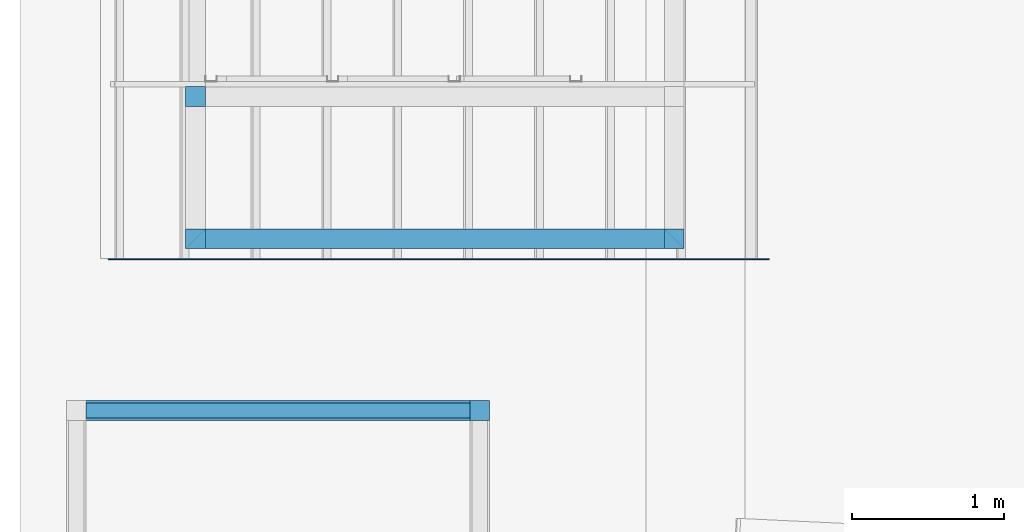
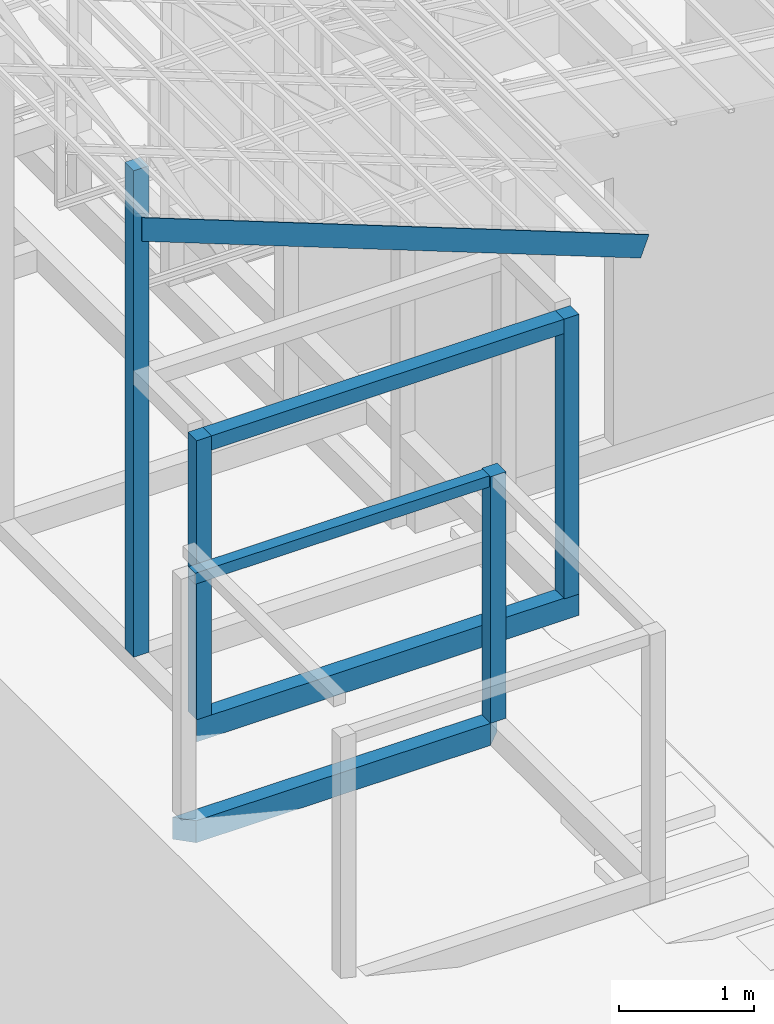
# One storey, part 2 of 22: 8 beams, 1 member.
"""IFC4 building model written with IfcOpenShell, lengths in millimetres."""

from ifc_helpers import new_model, entity, si_unit, converted_unit, frame, origin_with_axes, origin_2d_with_axis, place, context, subcontext, project, spatial, indexed_curve, rectangle, outline, extrude, clip, halfspace, material, material_profile, profile_set, profile_usage, type_object, element, save


model = new_model("IFC4")

# Units and contexts
model_context = context("Model", 3, precision=1e-05, world=origin_with_axes())
plan_context = context("Plan", 2, precision=1e-05, world=origin_2d_with_axis())
body_context = subcontext(model_context, "Body", "Model", "MODEL_VIEW")
ifc_project = project(units=[si_unit("VOLUMEUNIT", "CUBIC_METRE"), si_unit("LENGTHUNIT", "METRE", prefix="MILLI"), si_unit("AREAUNIT", "SQUARE_METRE"), converted_unit("PLANEANGLEUNIT", "degree", entity("IfcReal", 0.0174532925199433), si_unit("PLANEANGLEUNIT", "RADIAN"), dimensions=[0, 0, 0, 0, 0, 0, 0])], contexts=[model_context, plan_context])

# Site, building, storey
site_placement = place(None, origin_with_axes())
site = spatial("IfcSite", under=ifc_project, at=site_placement)
building_placement = place(site_placement, origin_with_axes())
building = spatial("IfcBuilding", under=site, at=building_placement, Name="2")
storey_placement = place(building_placement, frame((0.0, 0.0, 200.000002980232), z_axis=(0.0, 0.0, 1.0), x_axis=(1.0, 0.0, 0.0)))
storey = spatial("IfcBuildingStorey", under=building, at=storey_placement)

# Beams
ifc_material_1 = material(Name="Concrete")
ifc_material_profile_1 = material_profile(ifc_material_1, outline(indexed_curve([(-65.0, 99.9999923706055), (65.0, 99.9999923706055), (65.0, -99.9999923706055), (-65.0, -99.9999923706055), (-65.0, 99.9999923706055)])))
ifc_profile_set_1 = profile_set([ifc_material_profile_1])
ifc_profile_usage_1 = profile_usage(ifc_profile_set_1, cardinal=2)
beam_type_1 = type_object("IfcBeamType", PredefinedType="BEAM", material=ifc_profile_set_1)
beam_1_placement = place(storey_placement, frame((-7215.00015258789, 4065.00482559204, 535.000011324883), z_axis=(0.999999999999932, -1.9470714107682e-07, 3.13916473260157e-07), x_axis=(1.94707183709391e-07, 0.99999999999997, -1.49011611938472e-07)))
element("IfcBeam", 1, at=beam_1_placement, inside=storey, type_object=beam_type_1, material=ifc_profile_usage_1, Name="Beam", PredefinedType="BEAM", context=body_context, shape_type="Clipping", body=[
    clip(clip(extrude(outline(indexed_curve([(-65.0, 99.9999923706055), (65.0, 99.9999923706055), (65.0, -99.9999923706055), (-65.0, -99.9999923706055), (-65.0, 99.9999923706055)])), frame((0.0, 100.0, 0.0), z_axis=(0.0, 0.0, 1.0), x_axis=(1.0, 0.0, 0.0)), (0.0, 0.0, 1.0), 3280.00421035329), halfspace(frame((-65.0003477931023, -735.001564025879, 3280.00473976135), z_axis=(0.70710688829422, -1.95662650526174e-07, 0.707106649875641), x_axis=(-2.76708732110036e-07, -0.999999999999962, 0.0)), False)), halfspace(frame((-65.0000348687172, -735.000491142273, -0.000301992457707456), z_axis=(0.707106649875641, 2.43045974457345e-07, -0.70710688829422), x_axis=(3.43718977186929e-07, -0.999999999999941, 0.0)), False)),
])
ifc_profile_usage_2 = profile_usage(ifc_profile_set_1, cardinal=1)
beam_2_placement = place(storey_placement, frame((-7999.99475479126, 3000.00619888306, 534.999772906304), z_axis=(0.999999999999535, -5.52334881831227e-07, 7.90753631462936e-07), x_axis=(5.52335052361641e-07, 0.999999999999819, -2.38418493836391e-07)))
element("IfcBeam", 2, at=beam_2_placement, inside=storey, type_object=beam_type_1, material=ifc_profile_usage_2, Name="Beam", PredefinedType="BEAM", context=body_context, shape_type="Clipping", body=[
    clip(clip(extrude(outline(indexed_curve([(-65.0, 99.9999923706055), (65.0, 99.9999923706055), (65.0, -99.9999923706055), (-65.0, -99.9999923706055), (-65.0, 99.9999923706055)])), frame((-65.0000076293945, 100.0, 0.0), z_axis=(0.0, 0.0, 1.0), x_axis=(1.0, 0.0, 0.0)), (0.0, 0.0, 1.0), 2785.00036202087), halfspace(frame((-1.94011402498973e-05, -735.002815723419, 2784.99960899353), z_axis=(-0.707106351852417, -5.42005977877125e-07, 0.707107186317444), x_axis=(-7.66512670204509e-07, 0.999999999999706, 0.0)), False)), halfspace(frame((0.0001112751917276, -734.999299049377, -0.000703333228102565), z_axis=(-0.707107186317444, 6.65917013975559e-07, -0.707106351852417), x_axis=(9.41748333012007e-07, 0.999999999999557, 0.0)), False)),
])
ifc_material_profile_2 = material_profile(ifc_material_1, rectangle(XDim=130.000015258789, YDim=130.000015258789, kind="CURVE"))
ifc_profile_set_2 = profile_set([ifc_material_profile_2])
ifc_profile_usage_3 = profile_usage(ifc_profile_set_2, cardinal=5)
beam_type_2 = type_object("IfcBeamType", PredefinedType="BEAM", material=ifc_profile_set_2)
beam_3_placement = place(storey_placement, frame((-7150.00057220459, 4065.00482559204, 735.000118613243), z_axis=(0.0, 0.0, 1.0), x_axis=(1.0, 0.0, 0.0)))
element("IfcBeam", 3, at=beam_3_placement, inside=storey, type_object=beam_type_2, material=ifc_profile_usage_3, Name="Column", PredefinedType="BEAM", context=body_context, shape_type="SweptSolid", body=[
    extrude(rectangle(XDim=130.000015258789, YDim=130.000015258789, kind="CURVE"), origin_with_axes(), (0.0, 0.0, 1.0), 2530.00355867279),
])
ifc_profile_usage_4 = profile_usage(ifc_profile_set_2, cardinal=5)
beam_4_placement = place(storey_placement, frame((-3999.99856948853, 4065.00434875488, 728.171870112419), z_axis=(0.0, 0.0, 1.0), x_axis=(1.0, 0.0, 0.0)))
element("IfcBeam", 4, at=beam_4_placement, inside=storey, type_object=beam_type_2, material=ifc_profile_usage_4, Name="Column", PredefinedType="BEAM", context=body_context, shape_type="SweptSolid", body=[
    extrude(rectangle(XDim=130.000015258789, YDim=130.000015258789, kind="CURVE"), origin_with_axes(), (0.0, 0.0, 1.0), 2536.83157700176),
])
ifc_profile_usage_5 = profile_usage(ifc_profile_set_2, cardinal=5)
beam_5_placement = place(storey_placement, frame((-7150.00057220459, 5000.00047683716, 735.000118613243), z_axis=(0.0, 0.0, 1.0), x_axis=(1.0, 0.0, 0.0)))
element("IfcBeam", 5, at=beam_5_placement, inside=storey, type_object=beam_type_2, material=ifc_profile_usage_5, Name="Column", PredefinedType="BEAM", context=body_context, shape_type="SweptSolid", body=[
    extrude(rectangle(XDim=130.000015258789, YDim=130.000015258789, kind="CURVE"), origin_with_axes(), (0.0, 0.0, 1.0), 4411.20902133499),
])
ifc_profile_usage_6 = profile_usage(ifc_profile_set_2, cardinal=5)
beam_6_placement = place(storey_placement, frame((-5279.99448776245, 2935.00447273254, 735.00095307827), z_axis=(0.0, 0.0, 1.0), x_axis=(1.0, 0.0, 0.0)))
element("IfcBeam", 6, at=beam_6_placement, inside=storey, type_object=beam_type_2, material=ifc_profile_usage_6, Name="Column", PredefinedType="BEAM", context=body_context, shape_type="SweptSolid", body=[
    extrude(rectangle(XDim=130.000015258789, YDim=130.000015258789, kind="CURVE"), origin_with_axes(), (0.0, 0.0, 1.0), 2235.00041611772),
])
ifc_material_profile_3 = material_profile(ifc_material_1, rectangle(XDim=130.000015258789, YDim=130.000015258789))
ifc_profile_set_3 = profile_set([ifc_material_profile_3])
ifc_profile_usage_7 = profile_usage(ifc_profile_set_3)
beam_type_3 = type_object("IfcBeamType", Name="Ring", PredefinedType="BEAM", material=ifc_profile_set_3)
beam_7_placement = place(storey_placement, frame((-7085.00051498413, 4065.00482559204, 3200.00247657299), z_axis=(0.999999999999932, -1.9470714107682e-07, 3.13916473260157e-07), x_axis=(1.94707183709391e-07, 0.99999999999997, -1.49011611938472e-07)))
element("IfcBeam", 7, at=beam_7_placement, inside=storey, type_object=beam_type_3, material=ifc_profile_usage_7, Name="Beam", PredefinedType="BEAM", context=body_context, shape_type="SweptSolid", body=[
    extrude(rectangle(XDim=130.000015258789, YDim=130.000015258789), origin_with_axes(), (0.0, 0.0, 1.0), 3020.00196570547),
])
ifc_material_profile_4 = material_profile(ifc_material_1, rectangle(XDim=100.0, YDim=100.0))
ifc_profile_set_4 = profile_set([ifc_material_profile_4])
ifc_profile_usage_8 = profile_usage(ifc_profile_set_4, cardinal=2)
beam_type_4 = type_object("IfcBeamType", PredefinedType="BEAM", material=ifc_profile_set_4)
beam_8_placement = place(storey_placement, frame((-7869.99464035034, 2935.00447273254, 2870.00088393688), z_axis=(0.999999999999535, -5.52334881831227e-07, 7.90753631462936e-07), x_axis=(5.52335052361641e-07, 0.999999999999819, -2.38418493836391e-07)))
element("IfcBeam", 8, at=beam_8_placement, inside=storey, type_object=beam_type_4, material=ifc_profile_usage_8, Name="Beam", PredefinedType="BEAM", context=body_context, shape_type="SweptSolid", body=[
    extrude(rectangle(XDim=100.0, YDim=100.0), frame((0.0, 50.0, 0.0), z_axis=(0.0, 0.0, 1.0), x_axis=(1.0, 0.0, 0.0)), (0.0, 0.0, 1.0), 2525.00059297894),
])

# Member
ifc_material_2 = material(Name="STEEL")
ifc_material_profile_5 = material_profile(ifc_material_2, rectangle(XDim=8.0, YDim=200.0, kind="CURVE"))
ifc_profile_set_5 = profile_set([ifc_material_profile_5])
ifc_profile_usage_9 = profile_usage(ifc_profile_set_5, cardinal=7)
member_type = type_object("IfcMemberType", PredefinedType="CHORD", material=ifc_profile_set_5)
member_placement = place(storey_placement, frame((-7911.04698181152, 3935.00256538391, 5583.38098227978), z_axis=(0.933001239807418, 5.51803577976232e-07, -0.359873153371458), x_axis=(-6.39757843145936e-07, 0.999999999999788, -1.25297731301517e-07)))
element("IfcMember", 9, at=member_placement, inside=storey, type_object=member_type, material=ifc_profile_usage_9, Name="Member", context=body_context, shape_type="Clipping", body=[
    clip(extrude(rectangle(XDim=8.0, YDim=200.0, kind="CURVE"), frame((-4.0, -100.0, 0.0), z_axis=(0.0, 0.0, 1.0), x_axis=(1.0, 0.0, 0.0)), (0.0, 0.0, 1.0), 4860.47083528471), halfspace(frame((13922.0037460327, 2.47931480407715, 199.050739407539), z_axis=(5.02834041071765e-07, -0.35987314581871, -0.933001220226288), x_axis=(-0.999999999999024, -1.39725357925034e-06, 0.0)), False)),
])

save(model, "model.ifc")
